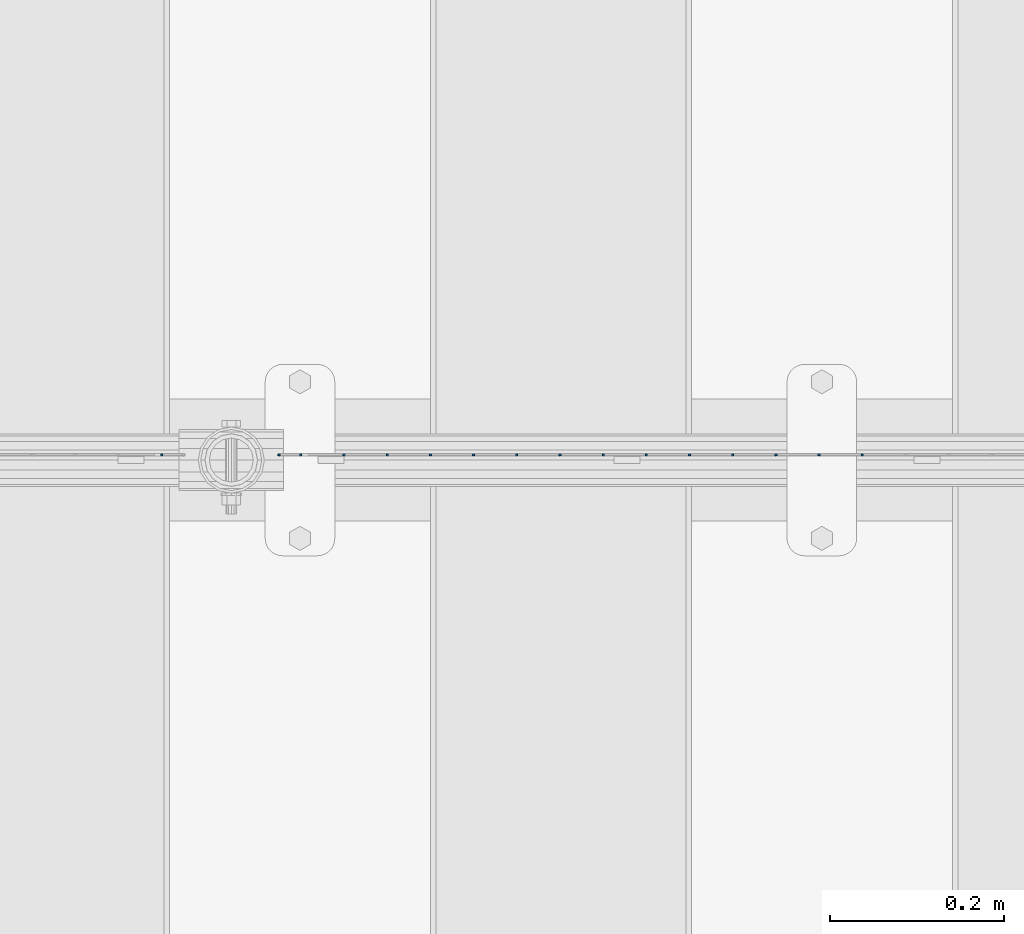
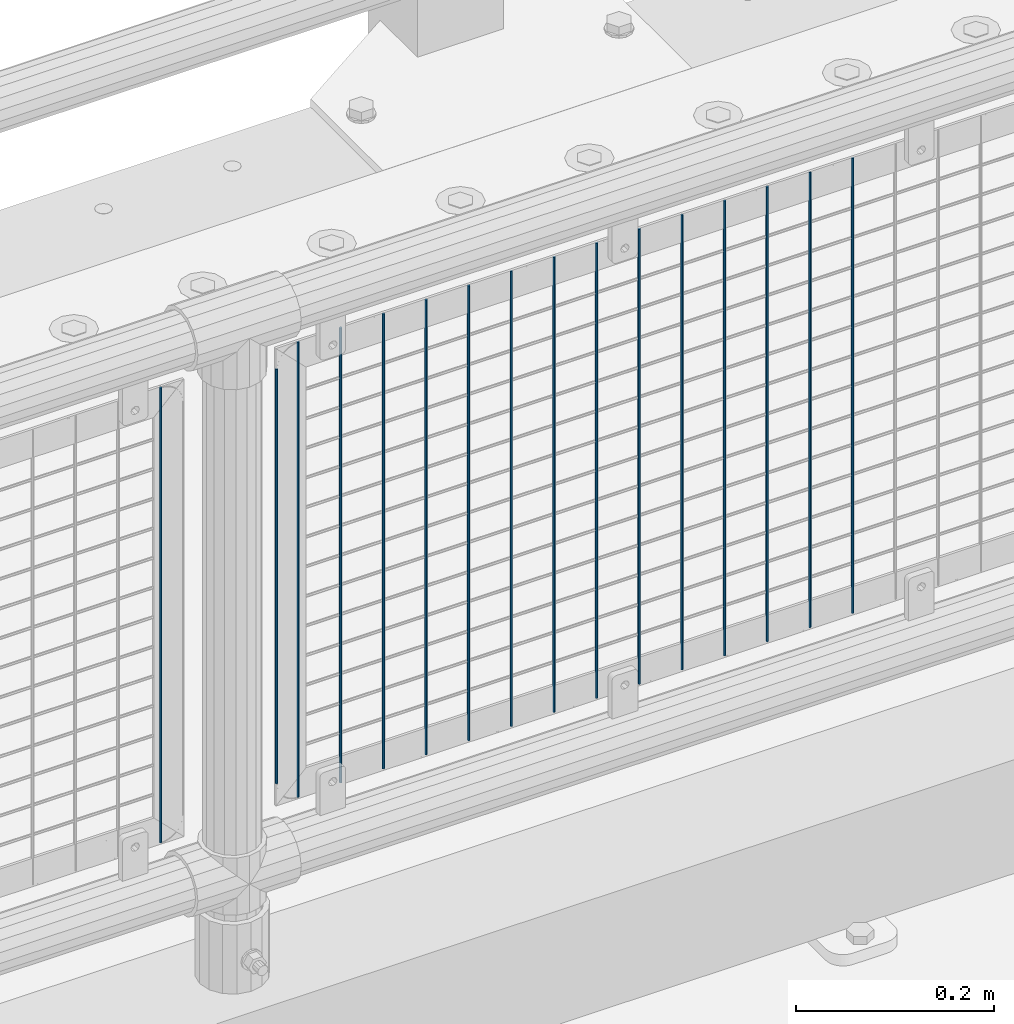
# One storey, part 86 of 257: 16 columns.
"""IFC2X3 building model written with IfcOpenShell, lengths in millimetres."""

from ifc_helpers import new_model, si_unit, frame, origin_with_axes, place, context, subcontext, project, spatial, faceted_brep, material, type_object, element, save


model = new_model("IFC2X3")

# Units and contexts
model_context = context("Model", 3, precision=1e-05, world=origin_with_axes())
body_context = subcontext(model_context, "Body", "Model", "MODEL_VIEW")
ifc_project = project(units=[si_unit("LENGTHUNIT", "METRE", prefix="MILLI"), si_unit("AREAUNIT", "SQUARE_METRE"), si_unit("VOLUMEUNIT", "CUBIC_METRE"), si_unit("MASSUNIT", "GRAM", prefix="KILO"), si_unit("TIMEUNIT", "SECOND"), si_unit("PLANEANGLEUNIT", "RADIAN"), si_unit("SOLIDANGLEUNIT", "STERADIAN"), si_unit("THERMODYNAMICTEMPERATUREUNIT", "DEGREE_CELSIUS"), si_unit("LUMINOUSINTENSITYUNIT", "LUMEN")], contexts=[model_context])

# Site, building, storey
site_placement = place(None, origin_with_axes())
site = spatial("IfcSite", under=ifc_project, at=site_placement, CompositionType="ELEMENT")
building_placement = place(site_placement, origin_with_axes())
building = spatial("IfcBuilding", under=site, at=building_placement, Name="Standard", CompositionType="ELEMENT")
storey_placement = place(building_placement, origin_with_axes())
storey = spatial("IfcBuildingStorey", under=building, at=storey_placement, Name="Undefined", CompositionType="ELEMENT", Elevation=0.0)

# Columns
ifc_material = material(Name="Misc_Undefined")
column_type = type_object("IfcColumnType", Name="D3", PredefinedType="NOTDEFINED")
for number, where, z_axis, x_axis in (
    (1, (53396.515, 10670.5, 353.020000000004), (-1.0, 0.0, 0.0), (0.0, 0.0, 1.0)),
    (2, (53346.86, 10670.5, 353.020000000004), (-1.0, 0.0, 0.0), (0.0, 0.0, 1.0)),
    (3, (53297.205, 10670.5, 353.020000000004), (-1.0, 0.0, 0.0), (0.0, 0.0, 1.0)),
    (4, (53247.55, 10670.5, 353.020000000004), (-1.0, 0.0, 0.0), (0.0, 0.0, 1.0)),
    (5, (53197.895, 10670.5, 353.020000000004), (-1.0, 0.0, 0.0), (0.0, 0.0, 1.0)),
    (6, (53148.24, 10670.5, 353.020000000004), (-1.0, 0.0, 0.0), (0.0, 0.0, 1.0)),
    (7, (53098.585, 10670.5, 353.020000000004), (-1.0, 0.0, 0.0), (0.0, 0.0, 1.0)),
    (8, (53048.93, 10670.5, 353.020000000004), (-1.0, 0.0, 0.0), (0.0, 0.0, 1.0)),
    (9, (52999.275, 10670.5, 353.020000000004), (-1.0, 0.0, 0.0), (0.0, 0.0, 1.0)),
    (10, (52949.62, 10670.5, 353.020000000004), (-1.0, 0.0, 0.0), (0.0, 0.0, 1.0)),
    (11, (52899.965, 10670.5, 353.020000000004), (-1.0, 0.0, 0.0), (0.0, 0.0, 1.0)),
    (12, (52850.3103448276, 10670.5, 353.020000000004), (-1.0, 0.0, 0.0), (0.0, 0.0, 1.0)),
    (13, (52800.6551724138, 10670.5, 353.020000000004), (-0.999999999962839, 0.0, 8.62099999968473e-06), (8.62099999949798e-06, 0.0, 0.999999999962839)),
):
    element("IfcColumn", number, at=place(storey_placement, frame(where, z_axis=z_axis, x_axis=x_axis)), inside=storey, type_object=column_type, material=ifc_material, ObjectType="D3", context=body_context, shape_type="Brep", body=[
        faceted_brep([(0.0, -1.5, -5.6843418860808e-14), (0.0, -0.750000000001819, -1.29903810567669), (560.0, -0.75, -1.29903810567339), (560.0, -1.5, 0.0), (7.27595761418343e-12, 0.749999999998181, -1.29903810567669), (560.0, 0.75, -1.29903810567339), (0.0, 1.5, -5.6843418860808e-14), (560.0, 1.5, 0.0), (7.27595761418343e-12, 0.749999999998181, 1.29903810567669), (560.0, 0.75, 1.29903810567339), (0.0, -0.750000000001819, 1.29903810567669), (560.0, -0.75, 1.29903810567339)], [[[0, 1, 2, 3]], [[1, 4, 5, 2]], [[4, 6, 7, 5]], [[6, 8, 9, 7]], [[8, 10, 11, 9]], [[10, 0, 3, 11]], [[5, 7, 9, 11, 3, 2]], [[10, 8, 6, 4, 1, 0]]]),
    ])
column_placement = place(storey_placement, frame((52726.0, 10670.5, 378.020000000004), z_axis=(-1.0, 0.0, 0.0), x_axis=(0.0, 0.0, 1.0)))
element("IfcColumn", 14, at=column_placement, inside=storey, type_object=column_type, material=ifc_material, ObjectType="D3", context=body_context, shape_type="Brep", body=[
    faceted_brep([(0.0, -1.5, -5.6843418860808e-14), (0.0, -0.750000000001819, -1.29903810567669), (510.0, -0.75, -1.29903810567339), (510.0, -1.5, 0.0), (7.27595761418343e-12, 0.749999999998181, -1.29903810567669), (510.0, 0.75, -1.29903810567339), (0.0, 1.5, -5.6843418860808e-14), (510.0, 1.5, 0.0), (7.27595761418343e-12, 0.749999999998181, 1.29903810567669), (510.0, 0.75, 1.29903810567339), (0.0, -0.750000000001819, 1.29903810567669), (510.0, -0.75, 1.29903810567339)], [[[0, 1, 2, 3]], [[1, 4, 5, 2]], [[4, 6, 7, 5]], [[6, 8, 9, 7]], [[8, 10, 11, 9]], [[10, 0, 3, 11]], [[5, 7, 9, 11, 3, 2]], [[10, 8, 6, 4, 1, 0]]]),
])
for number, where, z_axis, x_axis in (
    (15, (52751.0, 10670.5, 353.020000000004), (-1.0, 0.0, 0.0), (0.0, 0.0, 1.0)),
    (16, (52590.995, 10670.5, 353.020000000003), (-1.0, 0.0, 0.0), (0.0, 0.0, 1.0)),
):
    element("IfcColumn", number, at=place(storey_placement, frame(where, z_axis=z_axis, x_axis=x_axis)), inside=storey, type_object=column_type, material=ifc_material, ObjectType="D3", context=body_context, shape_type="Brep", body=[
        faceted_brep([(0.0, -1.5, -5.6843418860808e-14), (0.0, -0.750000000001819, -1.29903810567669), (560.0, -0.75, -1.29903810567339), (560.0, -1.5, 0.0), (7.27595761418343e-12, 0.749999999998181, -1.29903810567669), (560.0, 0.75, -1.29903810567339), (0.0, 1.5, -5.6843418860808e-14), (560.0, 1.5, 0.0), (7.27595761418343e-12, 0.749999999998181, 1.29903810567669), (560.0, 0.75, 1.29903810567339), (0.0, -0.750000000001819, 1.29903810567669), (560.0, -0.75, 1.29903810567339)], [[[0, 1, 2, 3]], [[1, 4, 5, 2]], [[4, 6, 7, 5]], [[6, 8, 9, 7]], [[8, 10, 11, 9]], [[10, 0, 3, 11]], [[5, 7, 9, 11, 3, 2]], [[10, 8, 6, 4, 1, 0]]]),
    ])

save(model, "model.ifc")
